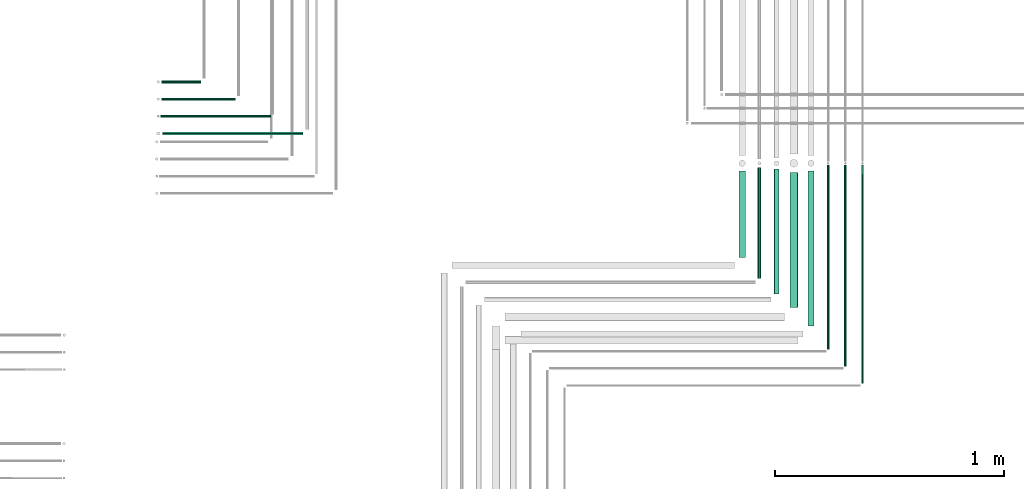
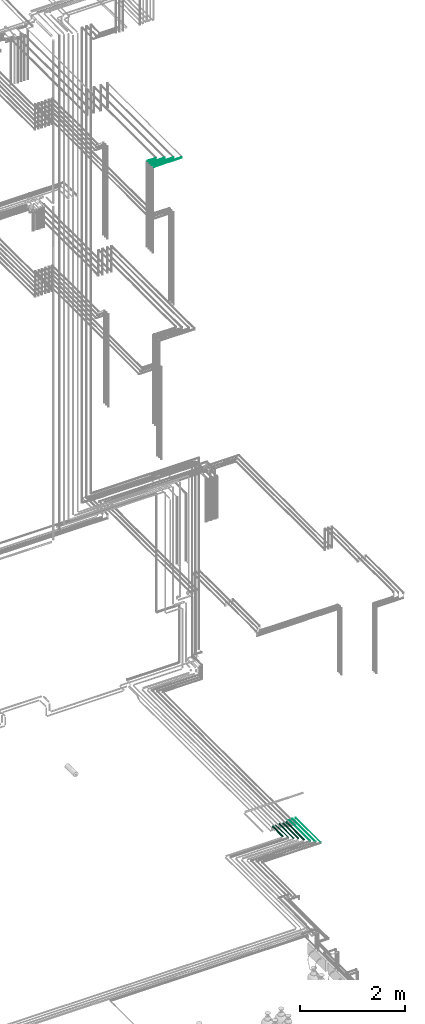
# One storey, part 209 of 331: 12 flow segments.
"""IFC2X3 building model written with IfcOpenShell, lengths in millimetres."""

from ifc_helpers import new_model, entity, si_unit, converted_unit, derived_unit, direction, frame, frame_2d, origin, origin_2d_with_axis, place, context, subcontext, project, spatial, circle, extrude, type_object, element, save


model = new_model("IFC2X3")

# Units and contexts
model_context = context("Model", 3, precision=0.01, world=origin(), true_north=direction((6.12303176911189e-17, 1.0)))
body_context = subcontext(model_context, "Body", "Model", "MODEL_VIEW")
ifc_project = project(units=[si_unit("LENGTHUNIT", "METRE", prefix="MILLI"), si_unit("AREAUNIT", "SQUARE_METRE"), si_unit("VOLUMEUNIT", "CUBIC_METRE"), converted_unit("PLANEANGLEUNIT", "DEGREE", entity("IfcRatioMeasure", 0.0174532925199433), si_unit("PLANEANGLEUNIT", "RADIAN"), dimensions=[0, 0, 0, 0, 0, 0, 0]), si_unit("MASSUNIT", "GRAM", prefix="KILO"), derived_unit("MASSDENSITYUNIT", [(si_unit("MASSUNIT", "GRAM", prefix="KILO"), 1), (si_unit("LENGTHUNIT", "METRE"), -3)]), derived_unit("MOMENTOFINERTIAUNIT", [(si_unit("LENGTHUNIT", "METRE"), 4)]), si_unit("TIMEUNIT", "SECOND"), si_unit("FREQUENCYUNIT", "HERTZ"), si_unit("THERMODYNAMICTEMPERATUREUNIT", "DEGREE_CELSIUS"), derived_unit("THERMALTRANSMITTANCEUNIT", [(si_unit("MASSUNIT", "GRAM", prefix="KILO"), 1), (si_unit("THERMODYNAMICTEMPERATUREUNIT", "KELVIN"), -1), (si_unit("TIMEUNIT", "SECOND"), -3)]), derived_unit("VOLUMETRICFLOWRATEUNIT", [(si_unit("LENGTHUNIT", "METRE"), 3), (si_unit("TIMEUNIT", "SECOND"), -1)]), derived_unit("MASSFLOWRATEUNIT", [(si_unit("MASSUNIT", "GRAM", prefix="KILO"), 1), (si_unit("TIMEUNIT", "SECOND"), -1)]), derived_unit("ROTATIONALFREQUENCYUNIT", [(si_unit("TIMEUNIT", "SECOND"), -1)]), si_unit("ELECTRICCURRENTUNIT", "AMPERE"), si_unit("ELECTRICVOLTAGEUNIT", "VOLT"), si_unit("POWERUNIT", "WATT"), si_unit("FORCEUNIT", "NEWTON", prefix="KILO"), si_unit("ILLUMINANCEUNIT", "LUX"), si_unit("LUMINOUSFLUXUNIT", "LUMEN"), si_unit("LUMINOUSINTENSITYUNIT", "CANDELA"), derived_unit("USERDEFINED", [(si_unit("MASSUNIT", "GRAM", prefix="KILO"), -1), (si_unit("LENGTHUNIT", "METRE"), -2), (si_unit("TIMEUNIT", "SECOND"), 3), (si_unit("LUMINOUSFLUXUNIT", "LUMEN"), 1)]), derived_unit("LINEARVELOCITYUNIT", [(si_unit("LENGTHUNIT", "METRE"), 1), (si_unit("TIMEUNIT", "SECOND"), -1)]), si_unit("PRESSUREUNIT", "PASCAL"), derived_unit("USERDEFINED", [(si_unit("LENGTHUNIT", "METRE"), -2), (si_unit("MASSUNIT", "GRAM", prefix="KILO"), 1), (si_unit("TIMEUNIT", "SECOND"), -2)]), derived_unit("LINEARFORCEUNIT", [(si_unit("MASSUNIT", "GRAM", prefix="KILO"), 1), (si_unit("LENGTHUNIT", "METRE"), 1), (si_unit("TIMEUNIT", "SECOND"), -2), (si_unit("LENGTHUNIT", "METRE"), -1)]), derived_unit("PLANARFORCEUNIT", [(si_unit("MASSUNIT", "GRAM", prefix="KILO"), 1), (si_unit("LENGTHUNIT", "METRE"), 1), (si_unit("TIMEUNIT", "SECOND"), -2), (si_unit("LENGTHUNIT", "METRE"), -2)])], contexts=[model_context])

# Site, building, storey
site_placement = place(None, frame((0.0, -0.00077364408347762, 0.0)))
site = spatial("IfcSite", under=ifc_project, at=site_placement, CompositionType="ELEMENT")
building_placement = place(site_placement, origin())
building = spatial("IfcBuilding", under=site, at=building_placement, CompositionType="ELEMENT")
storey_placement = place(building_placement, origin())
storey = spatial("IfcBuildingStorey", under=building, at=storey_placement, CompositionType="ELEMENT", Elevation=0.0)

# Flow segments
pipe_segment_type = type_object("IfcPipeSegmentType", PredefinedType="NOTDEFINED")
flow_segment_1_placement = place(building_placement, frame((65609.5166309581, 1863.7499295945, 2834.40472776409)))
element("IfcFlowSegment", 1, at=flow_segment_1_placement, inside=storey, type_object=pipe_segment_type, context=body_context, shape_type="SweptSolid", body=[
    extrude(circle(Radius=14.0, at=origin_2d_with_axis()), frame((15.5952722359214, 0.0, 15.595272235916), z_axis=(0.0, 1.0, 0.0), x_axis=(1.0, 0.0, 0.0)), (0.0, 0.0, 1.0), 677.250019556145),
])
flow_segment_2_placement = place(building_placement, frame((65694.516630958, 1763.74992959452, 2844.4047277641)))
element("IfcFlowSegment", 2, at=flow_segment_2_placement, inside=storey, type_object=pipe_segment_type, context=body_context, shape_type="SweptSolid", body=[
    extrude(circle(Radius=4.0, at=origin_2d_with_axis()), frame((5.59527223592365, 0.0, 5.59527223591607), z_axis=(0.0, 1.0, 0.0), x_axis=(1.0, 0.0, 0.0)), (0.0, 0.0, 1.0), 802.250019556128),
])
flow_segment_3_placement = place(building_placement, frame((65769.516630958, 1688.74992959451, 2844.4047277641)))
element("IfcFlowSegment", 3, at=flow_segment_3_placement, inside=storey, type_object=pipe_segment_type, context=body_context, shape_type="SweptSolid", body=[
    extrude(circle(Radius=4.0, at=origin_2d_with_axis()), frame((5.59527223592365, 0.0, 5.59527223591607), z_axis=(0.0, 1.0, 0.0), x_axis=(1.0, 0.0, 0.0)), (0.0, 0.0, 1.0), 877.250019556131),
])
flow_segment_4_placement = place(building_placement, frame((65844.516630958, 1613.74992959451, 2844.40472776409)))
element("IfcFlowSegment", 4, at=flow_segment_4_placement, inside=storey, type_object=pipe_segment_type, context=body_context, shape_type="SweptSolid", body=[
    extrude(circle(Radius=4.0, at=origin_2d_with_axis()), frame((5.59527223592365, 0.0, 5.59527223591607), z_axis=(0.0, 1.0, 0.0), x_axis=(1.0, 0.0, 0.0)), (0.0, 0.0, 1.0), 952.25001955613),
])
flow_segment_5_placement = place(storey_placement, frame((62790.1118832776, 2922.34830470758, 19042.4047277641)))
element("IfcFlowSegment", 5, at=flow_segment_5_placement, inside=storey, type_object=pipe_segment_type, context=body_context, shape_type="SweptSolid", body=[
    extrude(circle(Radius=6.0, at=frame_2d((-2.70716782324598e-12, -2.16573425859679e-12), x_axis=(1.0, 0.0))), frame((0.0, 7.59527223591887, 7.59527223591887), z_axis=(1.0, 0.0, 0.0), x_axis=(0.0, 1.0, 0.0)), (0.0, 0.0, 1.0), 172.000000000022),
])
flow_segment_6_placement = place(storey_placement, frame((62790.1118832776, 2847.34830470758, 19042.4047277641)))
element("IfcFlowSegment", 6, at=flow_segment_6_placement, inside=storey, type_object=pipe_segment_type, context=body_context, shape_type="SweptSolid", body=[
    extrude(circle(Radius=6.0, at=frame_2d((-2.70716782324598e-12, -2.16573425859679e-12), x_axis=(1.0, 0.0))), frame((0.0, 7.59527223591887, 7.59527223591887), z_axis=(1.0, 0.0, 0.0), x_axis=(0.0, 1.0, 0.0)), (0.0, 0.0, 1.0), 322.000000000022),
])
flow_segment_7_placement = place(storey_placement, frame((62786.1118832776, 2774.34830470758, 19044.4047277641)))
element("IfcFlowSegment", 7, at=flow_segment_7_placement, inside=storey, type_object=pipe_segment_type, context=body_context, shape_type="SweptSolid", body=[
    extrude(circle(Radius=4.0, at=frame_2d((-3.79003495254437e-12, 0.0), x_axis=(1.0, 0.0))), frame((0.0, 5.59527223591986, 5.59527223591499), z_axis=(1.0, 0.0, 0.0), x_axis=(0.0, 1.0, 0.0)), (0.0, 0.0, 1.0), 480.000000000021),
])
flow_segment_8_placement = place(storey_placement, frame((62794.1118832776, 2695.84830470758, 19040.9047277641)))
element("IfcFlowSegment", 8, at=flow_segment_8_placement, inside=storey, type_object=pipe_segment_type, context=body_context, shape_type="SweptSolid", body=[
    extrude(circle(Radius=7.5, at=frame_2d((-3.24860138789518e-12, 0.0), x_axis=(1.0, 0.0))), frame((0.0, 9.09527223591907, 9.09527223591636), z_axis=(1.0, 0.0, 0.0), x_axis=(0.0, 1.0, 0.0)), (0.0, 0.0, 1.0), 614.000000000008),
])
flow_segment_9_placement = place(building_placement, frame((65309.5166309581, 2163.74992959451, 2834.40472776411)))
element("IfcFlowSegment", 9, at=flow_segment_9_placement, inside=storey, type_object=pipe_segment_type, context=body_context, shape_type="SweptSolid", body=[
    extrude(circle(Radius=14.0, at=origin_2d_with_axis()), frame((15.5952722359214, 0.0, 15.595272235916), z_axis=(0.0, 1.0, 0.0), x_axis=(1.0, 0.0, 0.0)), (0.0, 0.0, 1.0), 377.250019556133),
])
flow_segment_10_placement = place(building_placement, frame((65391.016630958, 2072.74992959451, 2840.90472776409)))
element("IfcFlowSegment", 10, at=flow_segment_10_placement, inside=storey, type_object=pipe_segment_type, context=body_context, shape_type="SweptSolid", body=[
    extrude(circle(Radius=7.5, at=origin_2d_with_axis()), frame((9.09527223593152, 0.0, 9.09527223591582), z_axis=(0.0, 1.0, 0.0), x_axis=(1.0, 0.0, 0.0)), (0.0, 0.0, 1.0), 484.250019556131),
])
flow_segment_11_placement = place(building_placement, frame((65462.516630958, 2003.74992959451, 2837.40472776409)))
element("IfcFlowSegment", 11, at=flow_segment_11_placement, inside=storey, type_object=pipe_segment_type, context=body_context, shape_type="SweptSolid", body=[
    extrude(circle(Radius=11.0, at=origin_2d_with_axis()), frame((12.5952722359221, 0.0, 12.5952722359161), z_axis=(0.0, 1.0, 0.0), x_axis=(1.0, 0.0, 0.0)), (0.0, 0.0, 1.0), 547.250019556135),
])
flow_segment_12_placement = place(building_placement, frame((65531.016630958, 1944.74992959451, 2830.90472776409)))
element("IfcFlowSegment", 12, at=flow_segment_12_placement, inside=storey, type_object=pipe_segment_type, context=body_context, shape_type="SweptSolid", body=[
    extrude(circle(Radius=17.5, at=origin_2d_with_axis()), frame((19.0952722359292, 0.0, 19.0952722359157), z_axis=(0.0, 1.0, 0.0), x_axis=(1.0, 0.0, 0.0)), (0.0, 0.0, 1.0), 590.250019556135),
])

save(model, "model.ifc")
